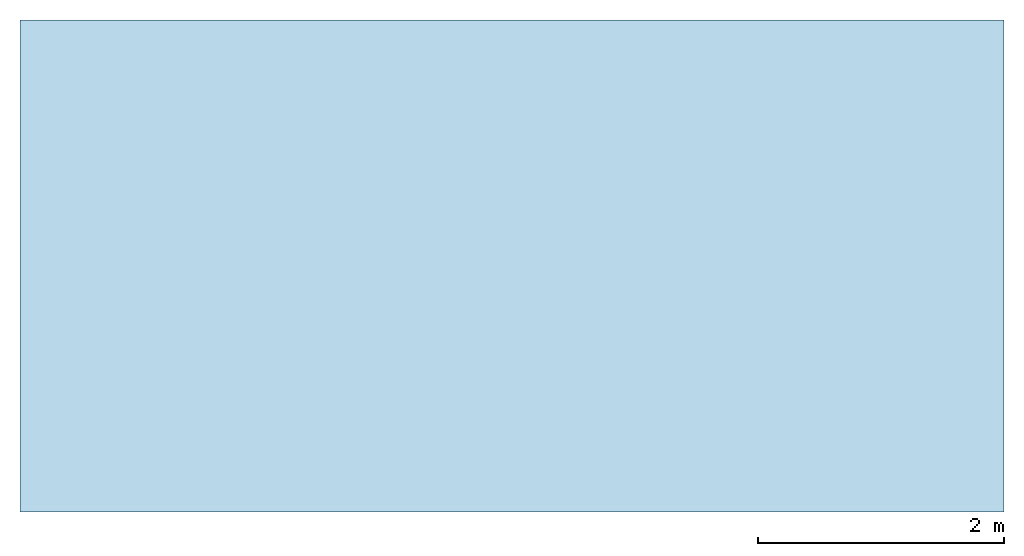
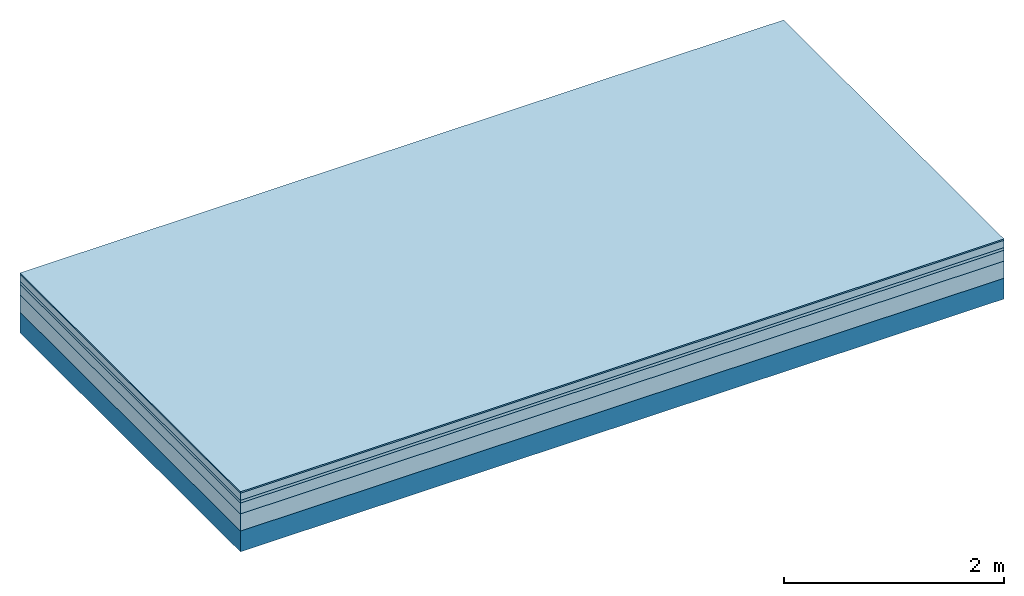
# One storey: 5 plates, 1 member, 1 element without a shape of its own.
"""IFC4 building model written with IfcOpenShell, lengths in metres."""

from ifc_helpers import new_model, si_unit, derived_unit, direction, frame, frame_2d, origin, origin_with_axes, place, context, project, spatial, rectangle, extrude, material, layer, layer_set, type_object, element, aggregate, save


model = new_model("IFC4")

# Units and contexts
plan_context = context("Plan", 3, precision=1e-05, world=origin(), true_north=direction((0.0, 1.0)))
model_context = context("Model", 3, precision=1e-05, world=origin(), true_north=direction((0.0, 1.0)))
ifc_project = project(units=[si_unit("LENGTHUNIT", "METRE"), derived_unit("SOUNDPRESSUREUNIT", [(si_unit("PRESSUREUNIT", "PASCAL", prefix="MICRO"), 0)]), si_unit("ENERGYUNIT", "JOULE", prefix="MEGA"), si_unit("MASSUNIT", "GRAM", prefix="KILO"), derived_unit("THERMALTRANSMITTANCEUNIT", [(si_unit("POWERUNIT", "WATT"), 1), (si_unit("AREAUNIT", "SQUARE_METRE"), -1), (si_unit("THERMODYNAMICTEMPERATUREUNIT", "KELVIN"), -1)]), derived_unit("AREADENSITYUNIT", [(si_unit("MASSUNIT", "GRAM", prefix="KILO"), 1), (si_unit("AREAUNIT", "SQUARE_METRE"), -1)]), derived_unit("USERDEFINED", [(si_unit("ENERGYUNIT", "JOULE", prefix="MEGA"), 1), (si_unit("AREAUNIT", "SQUARE_METRE"), -1)])], contexts=[plan_context, model_context])

# Site, building, storey
site = spatial("IfcSite", under=ifc_project)
building_placement = place(None, origin())
building = spatial("IfcBuilding", under=site, at=building_placement)
storey_placement = place(building_placement, origin())
storey = spatial("IfcBuildingStorey", under=building, at=storey_placement)

# Slab, member, plates
ifc_material_1 = material(Category="11.013")
ifc_layer_1 = layer(ifc_material_1, 0.015, Name="Flooring")
ifc_material_2 = material(Name="Cement screed", Category="04.006")
ifc_layer_2 = layer(ifc_material_2, 0.08, Name="On-material")
ifc_material_3 = material(Name="Wood fiber generic product", Category="10.009")
ifc_layer_3 = layer(ifc_material_3, 0.03, Name="Impact sound insulation")
ifc_material_4 = material(Name="Cement screed with EPS", Category="04.006")
ifc_layer_4 = layer(ifc_material_4, 0.12, Name="on Supporting structure")
ifc_material_5 = material(Category="01.002")
ifc_layer_5 = layer(ifc_material_5, 0.19, Name="Sub-floor")
ifc_material_6 = material(Name="Rigid, of the art")
ifc_layer_6 = layer(ifc_material_6, 0.0, Name="Bond")
ifc_layer_7 = layer(None, 0.23, Name="Supporting structure")
ifc_layer_set = layer_set([ifc_layer_1, ifc_layer_2, ifc_layer_3, ifc_layer_4, ifc_layer_5, ifc_layer_6, ifc_layer_7])
slab_type = type_object("IfcSlabType", Name="A2223", PredefinedType="NOTDEFINED", material=ifc_layer_set)
slab_placement = place(None, frame((0.0, 0.0, 0.0), z_axis=(0.0, 0.0, -1.0), x_axis=(1.0, 0.0, 0.0)))
slab = element("IfcSlab", 1, at=slab_placement, inside=storey, type_object=slab_type, material=ifc_layer_set, Name="Slab #1")
ifc_material_7 = material(Name="Solid timber panel")
member_placement = place(slab_placement, origin())
member = element("IfcMember", 2, at=member_placement, material=ifc_material_7, Name="Supporting structure", context=plan_context, shape_type="SweptSolid", body=[
    extrude(rectangle(XDim=1.0, YDim=0.23, at=frame_2d((0.5, 0.115), x_axis=(1.0, 0.0))), frame((0.0, 4.0, 0.435), z_axis=(0.0, -1.0, 0.0), x_axis=(1.0, 0.0, 0.0)), (0.0, 0.0, 1.0), 4.0),
    extrude(rectangle(XDim=1.0, YDim=0.23, at=frame_2d((0.5, 0.115), x_axis=(1.0, 0.0))), frame((1.0, 4.0, 0.435), z_axis=(0.0, -1.0, 0.0), x_axis=(1.0, 0.0, 0.0)), (0.0, 0.0, 1.0), 4.0),
    extrude(rectangle(XDim=1.0, YDim=0.23, at=frame_2d((0.5, 0.115), x_axis=(1.0, 0.0))), frame((2.0, 4.0, 0.435), z_axis=(0.0, -1.0, 0.0), x_axis=(1.0, 0.0, 0.0)), (0.0, 0.0, 1.0), 4.0),
    extrude(rectangle(XDim=1.0, YDim=0.23, at=frame_2d((0.5, 0.115), x_axis=(1.0, 0.0))), frame((3.0, 4.0, 0.435), z_axis=(0.0, -1.0, 0.0), x_axis=(1.0, 0.0, 0.0)), (0.0, 0.0, 1.0), 4.0),
    extrude(rectangle(XDim=1.0, YDim=0.23, at=frame_2d((0.5, 0.115), x_axis=(1.0, 0.0))), frame((4.0, 4.0, 0.435), z_axis=(0.0, -1.0, 0.0), x_axis=(1.0, 0.0, 0.0)), (0.0, 0.0, 1.0), 4.0),
    extrude(rectangle(XDim=1.0, YDim=0.23, at=frame_2d((0.5, 0.115), x_axis=(1.0, 0.0))), frame((5.0, 4.0, 0.435), z_axis=(0.0, -1.0, 0.0), x_axis=(1.0, 0.0, 0.0)), (0.0, 0.0, 1.0), 4.0),
    extrude(rectangle(XDim=1.0, YDim=0.23, at=frame_2d((0.5, 0.115), x_axis=(1.0, 0.0))), frame((6.0, 4.0, 0.435), z_axis=(0.0, -1.0, 0.0), x_axis=(1.0, 0.0, 0.0)), (0.0, 0.0, 1.0), 4.0),
    extrude(rectangle(XDim=1.0, YDim=0.23, at=frame_2d((0.5, 0.115), x_axis=(1.0, 0.0))), frame((7.0, 4.0, 0.435), z_axis=(0.0, -1.0, 0.0), x_axis=(1.0, 0.0, 0.0)), (0.0, 0.0, 1.0), 4.0),
])
plate_1_placement = place(slab_placement, origin())
plate_1 = element("IfcPlate", 3, at=plate_1_placement, material=ifc_material_1, Name="Flooring", context=plan_context, shape_type="SweptSolid", body=[
    extrude(rectangle(XDim=8.0, YDim=4.0, at=frame_2d((4.0, 2.0), x_axis=(1.0, 0.0))), origin_with_axes(), (0.0, 0.0, 1.0), 0.015),
])
plate_2_placement = place(slab_placement, origin())
plate_2 = element("IfcPlate", 4, at=plate_2_placement, material=ifc_material_2, Name="On-material", context=plan_context, shape_type="SweptSolid", body=[
    extrude(rectangle(XDim=8.0, YDim=4.0, at=frame_2d((4.0, 2.0), x_axis=(1.0, 0.0))), frame((0.0, 0.0, 0.015), z_axis=(0.0, 0.0, 1.0), x_axis=(1.0, 0.0, 0.0)), (0.0, 0.0, 1.0), 0.08),
])
plate_3_placement = place(slab_placement, origin())
plate_3 = element("IfcPlate", 5, at=plate_3_placement, material=ifc_material_3, Name="Impact sound insulation", context=plan_context, shape_type="SweptSolid", body=[
    extrude(rectangle(XDim=8.0, YDim=4.0, at=frame_2d((4.0, 2.0), x_axis=(1.0, 0.0))), frame((0.0, 0.0, 0.095), z_axis=(0.0, 0.0, 1.0), x_axis=(1.0, 0.0, 0.0)), (0.0, 0.0, 1.0), 0.03),
])
plate_4_placement = place(slab_placement, origin())
plate_4 = element("IfcPlate", 6, at=plate_4_placement, material=ifc_material_4, Name="on Supporting structure", context=plan_context, shape_type="SweptSolid", body=[
    extrude(rectangle(XDim=8.0, YDim=4.0, at=frame_2d((4.0, 2.0), x_axis=(1.0, 0.0))), frame((0.0, 0.0, 0.125), z_axis=(0.0, 0.0, 1.0), x_axis=(1.0, 0.0, 0.0)), (0.0, 0.0, 1.0), 0.12),
])
plate_5_placement = place(slab_placement, origin())
plate_5 = element("IfcPlate", 7, at=plate_5_placement, material=ifc_material_5, Name="Sub-floor", context=plan_context, shape_type="SweptSolid", body=[
    extrude(rectangle(XDim=8.0, YDim=4.0, at=frame_2d((4.0, 2.0), x_axis=(1.0, 0.0))), frame((0.0, 0.0, 0.245), z_axis=(0.0, 0.0, 1.0), x_axis=(1.0, 0.0, 0.0)), (0.0, 0.0, 1.0), 0.19),
])
aggregate(slab, [plate_1, plate_2, plate_3, plate_4, plate_5, member])

save(model, "model.ifc")
